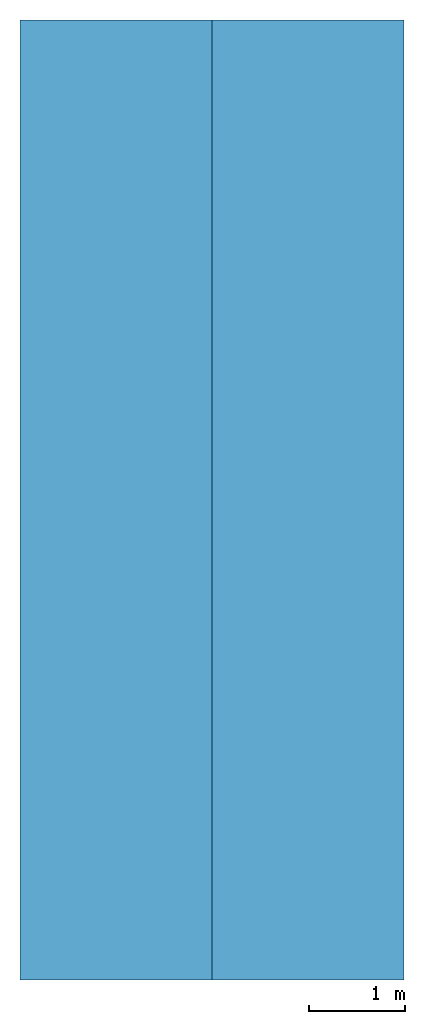
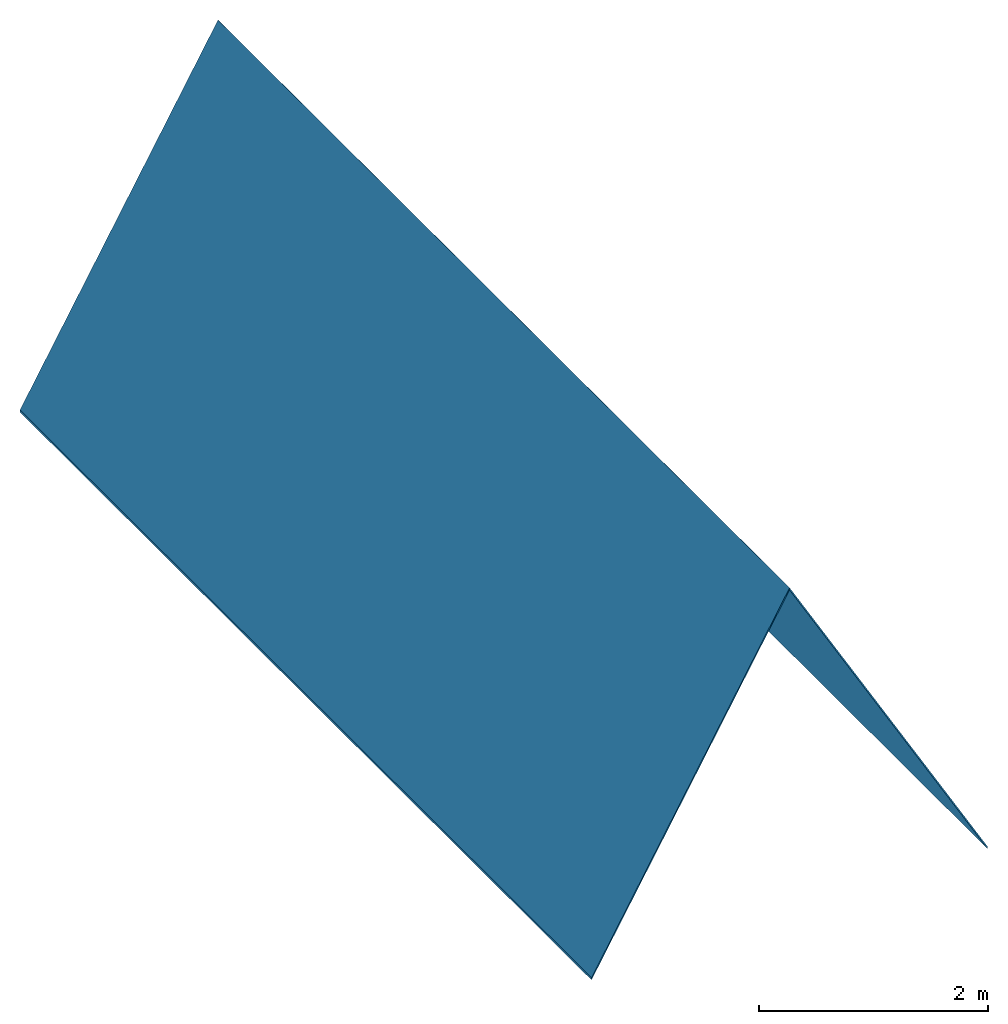
# One storey: 2 slabs, 2 elements without a shape of their own.
"""IFC2X3 building model written with IfcOpenShell, lengths in millimetres."""

from ifc_helpers import new_model, entity, si_unit, converted_unit, derived_unit, direction, frame, frame_2d, origin, place, context, subcontext, project, spatial, rectangle, extrude, material, layer, layer_set, element, aggregate, save


model = new_model("IFC2X3")

# Units and contexts
model_context = context("Model", 3, precision=0.01, world=origin(), true_north=direction((6.12303176911189e-17, 1.0)))
body_context = subcontext(model_context, "Body", "Model", "MODEL_VIEW")
ifc_project = project(units=[si_unit("LENGTHUNIT", "METRE", prefix="MILLI"), si_unit("AREAUNIT", "SQUARE_METRE"), si_unit("VOLUMEUNIT", "CUBIC_METRE"), converted_unit("PLANEANGLEUNIT", "DEGREE", entity("IfcRatioMeasure", 0.0174532925199433), si_unit("PLANEANGLEUNIT", "RADIAN"), dimensions=[0, 0, 0, 0, 0, 0, 0]), si_unit("MASSUNIT", "GRAM", prefix="KILO"), derived_unit("MASSDENSITYUNIT", [(si_unit("MASSUNIT", "GRAM", prefix="KILO"), 1), (si_unit("LENGTHUNIT", "METRE"), -3)]), si_unit("TIMEUNIT", "SECOND"), si_unit("FREQUENCYUNIT", "HERTZ"), si_unit("THERMODYNAMICTEMPERATUREUNIT", "DEGREE_CELSIUS"), derived_unit("THERMALTRANSMITTANCEUNIT", [(si_unit("MASSUNIT", "GRAM", prefix="KILO"), 1), (si_unit("THERMODYNAMICTEMPERATUREUNIT", "KELVIN"), -1), (si_unit("TIMEUNIT", "SECOND"), -3)]), derived_unit("VOLUMETRICFLOWRATEUNIT", [(si_unit("LENGTHUNIT", "METRE"), 3), (si_unit("TIMEUNIT", "SECOND"), -1)]), si_unit("ELECTRICCURRENTUNIT", "AMPERE"), si_unit("ELECTRICVOLTAGEUNIT", "VOLT"), si_unit("POWERUNIT", "WATT"), si_unit("FORCEUNIT", "NEWTON", prefix="KILO"), si_unit("ILLUMINANCEUNIT", "LUX"), si_unit("LUMINOUSFLUXUNIT", "LUMEN"), si_unit("LUMINOUSINTENSITYUNIT", "CANDELA"), derived_unit("USERDEFINED", [(si_unit("MASSUNIT", "GRAM", prefix="KILO"), -1), (si_unit("LENGTHUNIT", "METRE"), -2), (si_unit("TIMEUNIT", "SECOND"), 3), (si_unit("LUMINOUSFLUXUNIT", "LUMEN"), 1)]), derived_unit("LINEARVELOCITYUNIT", [(si_unit("LENGTHUNIT", "METRE"), 1), (si_unit("TIMEUNIT", "SECOND"), -1)]), si_unit("PRESSUREUNIT", "PASCAL"), derived_unit("USERDEFINED", [(si_unit("LENGTHUNIT", "METRE"), -2), (si_unit("MASSUNIT", "GRAM", prefix="KILO"), 1), (si_unit("TIMEUNIT", "SECOND"), -2)])], contexts=[model_context])

# Site, building, storey
site_placement = place(None, origin())
site = spatial("IfcSite", under=ifc_project, at=site_placement, CompositionType="ELEMENT")
building_placement = place(site_placement, origin())
building = spatial("IfcBuilding", under=site, at=building_placement, CompositionType="ELEMENT")
storey_placement = place(building_placement, frame((0.0, 0.0, 3000.0)))
storey = spatial("IfcBuildingStorey", under=building, at=storey_placement, Name="CEILING LEVEL", CompositionType="ELEMENT", Elevation=3000.00000000014)

# Roof, slab
roof_1_placement = place(storey_placement, frame((182473.234552934, 37012.9193803935, -3844.95516852847)))
roof_1 = element("IfcRoof", 1, at=roof_1_placement, inside=storey, Name="Basic Roof:CEILING:6003", ObjectType="Basic Roof:CEILING", ShapeType="NOTDEFINED")
ifc_material = material(Name="Default Roof")
ifc_layer = layer(ifc_material, 12.0)
ifc_layer_set = layer_set([ifc_layer], Name="Basic Roof:CEILING")
slab_1_placement = place(roof_1_placement, origin())
slab_1 = element("IfcSlab", 2, at=slab_1_placement, material=ifc_layer_set, Name="Basic Roof:CEILING:6003", ObjectType="Basic Roof:CEILING", PredefinedType="ROOF", context=body_context, shape_type="SweptSolid", body=[
    extrude(rectangle(XDim=3999.99999999999, YDim=10000.0, at=frame_2d((3.44471118296497e-11, 4.54747350886464e-12), x_axis=(-1.0, 0.0))), frame((1000.0, 5000.0, 1732.05080756887), z_axis=(0.866025403784438, 0.0, 0.500000000000001), x_axis=(0.500000000000001, 0.0, -0.866025403784438)), (-0.866025403784438, 0.0, 0.500000000000001), 24.0),
])
aggregate(roof_1, [slab_1])

roof_2_placement = place(storey_placement, frame((180472.234552934, 37012.9193803935, -3844.95516852847)))
roof_2 = element("IfcRoof", 3, at=roof_2_placement, inside=storey, Name="Basic Roof:CEILING:6010", ObjectType="Basic Roof:CEILING", ShapeType="NOTDEFINED")
slab_2_placement = place(roof_2_placement, origin())
slab_2 = element("IfcSlab", 4, at=slab_2_placement, material=ifc_layer_set, Name="Basic Roof:CEILING:6010", ObjectType="Basic Roof:CEILING", PredefinedType="ROOF", context=body_context, shape_type="SweptSolid", body=[
    extrude(rectangle(XDim=3999.99999999999, YDim=10000.0, at=frame_2d((-3.44471118296497e-11, 4.54747350886464e-12), x_axis=(-1.0, 0.0))), frame((1000.0, 5000.0, 1732.05080756887), z_axis=(-0.866025403784438, 0.0, 0.500000000000001), x_axis=(0.500000000000001, 0.0, 0.866025403784438)), (0.866025403784438, 0.0, 0.500000000000001), 24.0),
])
aggregate(roof_2, [slab_2])

save(model, "model.ifc")
